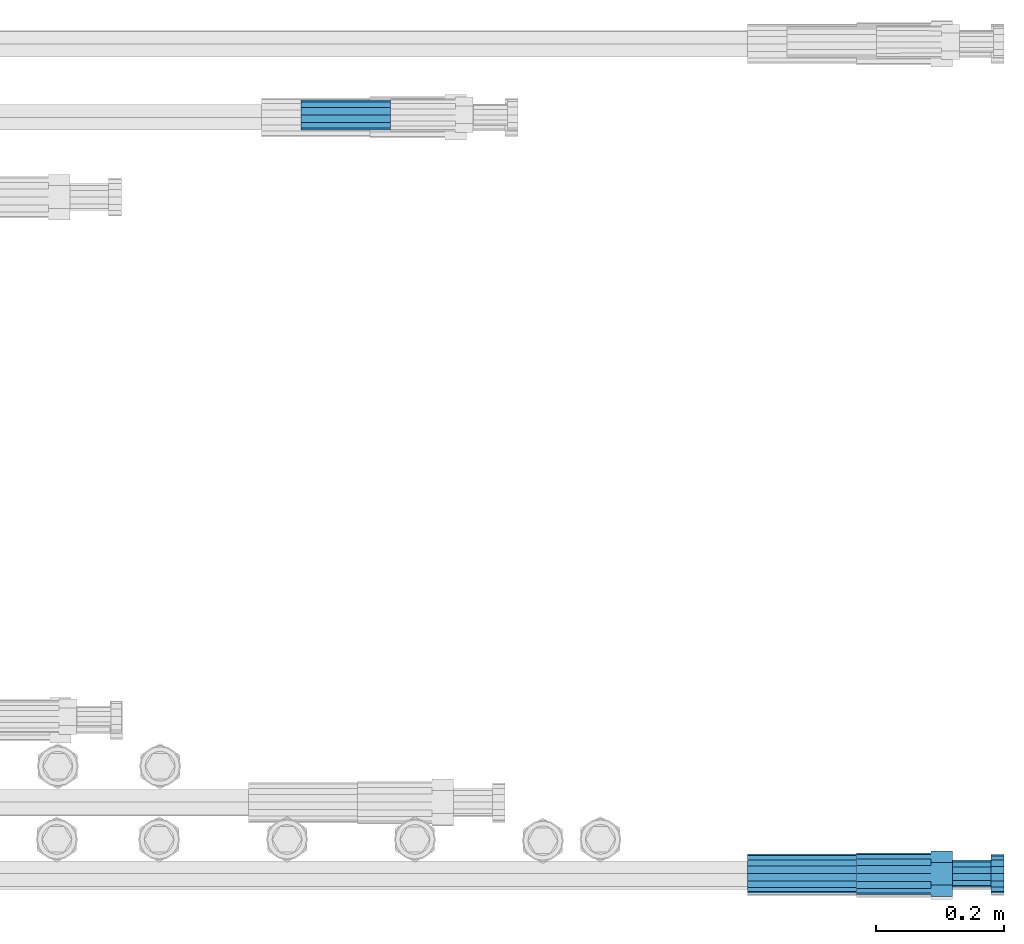
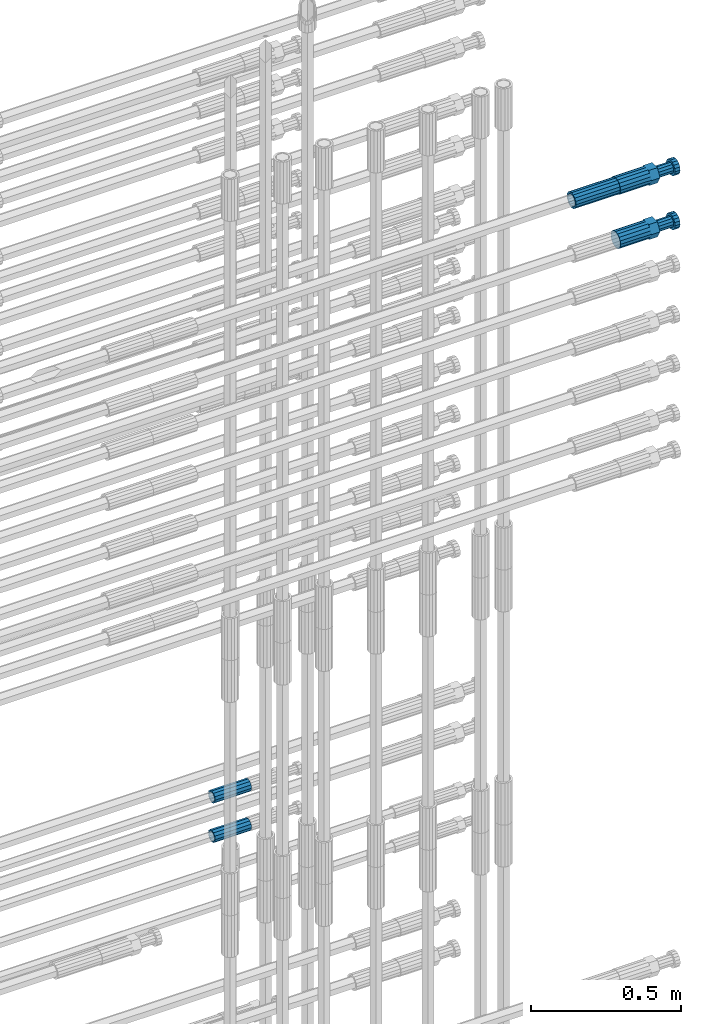
# One storey, part 107 of 119: 5 beams.
"""IFC2X3 building model written with IfcOpenShell, lengths in millimetres."""

from ifc_helpers import new_model, si_unit, frame, origin_with_axes, place, context, subcontext, project, spatial, faceted_brep, material, type_object, element, save


model = new_model("IFC2X3")

# Units and contexts
model_context = context("Model", 3, precision=1e-05, world=origin_with_axes())
body_context = subcontext(model_context, "Body", "Model", "MODEL_VIEW")
ifc_project = project(units=[si_unit("LENGTHUNIT", "METRE", prefix="MILLI"), si_unit("AREAUNIT", "SQUARE_METRE"), si_unit("VOLUMEUNIT", "CUBIC_METRE"), si_unit("MASSUNIT", "GRAM", prefix="KILO"), si_unit("TIMEUNIT", "SECOND"), si_unit("PLANEANGLEUNIT", "RADIAN"), si_unit("SOLIDANGLEUNIT", "STERADIAN"), si_unit("THERMODYNAMICTEMPERATUREUNIT", "DEGREE_CELSIUS"), si_unit("LUMINOUSINTENSITYUNIT", "LUMEN")], contexts=[model_context])

# Site, building, storey
site_placement = place(None, origin_with_axes())
site = spatial("IfcSite", under=ifc_project, at=site_placement, CompositionType="ELEMENT")
building_placement = place(site_placement, origin_with_axes())
building = spatial("IfcBuilding", under=site, at=building_placement, Name="Undefined", CompositionType="ELEMENT")
storey_placement = place(building_placement, origin_with_axes())
storey = spatial("IfcBuildingStorey", under=building, at=storey_placement, Name="Undefined", CompositionType="ELEMENT", Elevation=0.0)

# Beams
ifc_material = material(Name="STEEL/S275")
beam_type_1 = type_object("IfcBeamType", PredefinedType="NOTDEFINED")
beam_1_placement = place(storey_placement, frame((2039349.03023304, 6205102.98994599, 22308.9894123177), z_axis=(0.0, 0.0, 1.0), x_axis=(1.0, 0.0, 0.0)))
element("IfcBeam", 1, at=beam_1_placement, inside=storey, type_object=beam_type_1, material=ifc_material, Name="AG40N", context=body_context, shape_type="Brep", body=[
    faceted_brep([(1.62981450557709e-09, -23.4999999990687, 0.0), (7.45058059692383e-09, -21.7111690142192, 8.99306066057534), (170.000002125278, -21.711168999318, 8.99306066022245), (170.000002127141, -23.4999999844003, -3.66071617463604e-10), (4.65661287307739e-09, -16.6170093587134, 16.6170093578889), (170.000002122484, -16.6170093440451, 16.6170093575288), (1.86264514923096e-09, -8.99306066217832, 21.7111690140277), (170.000002118759, -8.99306064750999, 21.7111690136603), (2.3283064365387e-10, 9.31322574615479e-10, 23.5), (170.000002114102, 1.28056854009628e-08, 23.4999999996485), (-6.51925802230835e-09, 8.99306065868586, 21.7111690140241), (170.00000211224, 8.99306067335419, 21.7111690136639), (-7.45058059692383e-09, 16.6170093561523, 16.6170093578853), (170.000002109446, 16.6170093708206, 16.6170093575324), (-9.31322574615479e-09, 21.711169013055, 8.99306066057534), (170.000002108514, 21.7111690277234, 8.99306066022245), (-1.16415321826935e-09, 23.5000000009313, 0.0), (170.000002108514, 23.5000000144355, -3.66071617463604e-10), (-8.38190317153931e-09, 21.7111690151505, -8.99306066059444), (170.000002110377, 21.7111690300517, -8.9930606609546), (-5.58793544769287e-09, 16.6170093598776, -16.6170093579008), (170.000002113171, 16.6170093745459, -16.6170093582609), (-9.31322574615479e-10, 8.99306066334248, -21.7111690140396), (170.000002115965, 8.99306067801081, -21.7111690143961), (2.3283064365387e-10, 9.31322574615479e-10, -23.5), (170.00000211969, 1.7927959561348e-08, -23.5000000003843), (5.58793544769287e-09, -8.99306065752171, -21.7111690140396), (170.000002123415, -8.99306064285338, -21.7111690143961), (8.38190317153931e-09, -16.6170093549881, -16.6170093579008), (170.000002125278, -16.6170093403198, -16.6170093582646), (9.31322574615479e-09, -21.7111690121237, -8.99306066059444), (170.000002127141, -21.7111689972226, -8.9930606609546), (1.11758708953857e-08, -30.4999999990687, -9.54969436861575e-12), (1.30385160446167e-08, -28.1783257392235, -11.6718446871514), (170.000002129003, -28.1783257243223, -11.6718446875116), (170.000002129935, -30.4999999841675, -3.66071617463604e-10), (1.02445483207703e-08, -21.5667568228673, -21.5667568262129), (170.000002128072, -21.566756808199, -21.5667568265694), (7.45058059692383e-09, -11.6718446831219, -28.1783257416196), (170.000002125278, -11.6718446684536, -28.1783257419834), (3.72529029846191e-09, 3.95812094211578e-09, -30.5000000000277), (170.00000211969, 1.83936208486557e-08, -30.5000000003879), (-9.31322574615479e-10, 11.6718446905725, -28.1783257416232), (170.000002115965, 11.6718447052408, -28.1783257419797), (-6.51925802230835e-09, 21.5667568286881, -21.5667568262093), (170.000002110377, 21.5667568433564, -21.5667568265694), (-9.31322574615479e-09, 28.178325742716, -11.6718446871478), (170.000002108514, 28.1783257573843, -11.6718446875079), (-1.21071934700012e-08, 30.5, -5.91171556152403e-12), (170.000002106652, 30.5000000144355, -3.62433638656512e-10), (-1.21071934700012e-08, 28.1783257401548, 11.6718446871359), (170.00000210572, 28.1783257548232, 11.6718446867794), (-1.02445483207703e-08, 21.5667568240315, 21.5667568261974), (170.000002107583, 21.566756838467, 21.5667568258409), (-7.45058059692383e-09, 11.671844684286, 28.1783257416041), (170.000002110377, 11.6718446989544, 28.178325741244), (-2.79396772384644e-09, -2.56113708019257e-09, 30.5000000000159), (170.000002114102, 1.18743628263474e-08, 30.4999999996558), (1.86264514923096e-09, -11.6718446896411, 28.1783257416114), (170.000002118759, -11.67184467474, 28.178325741244), (7.45058059692383e-09, -21.5667568275239, 21.5667568261974), (170.000002123415, -21.5667568126228, 21.5667568258373), (1.02445483207703e-08, -28.1783257415518, 11.6718446871359), (170.000002127141, -28.1783257271163, 11.6718446867794)], [[[0, 1, 2, 3]], [[1, 4, 5, 2]], [[4, 6, 7, 5]], [[6, 8, 9, 7]], [[8, 10, 11, 9]], [[10, 12, 13, 11]], [[12, 14, 15, 13]], [[14, 16, 17, 15]], [[16, 18, 19, 17]], [[18, 20, 21, 19]], [[20, 22, 23, 21]], [[22, 24, 25, 23]], [[24, 26, 27, 25]], [[26, 28, 29, 27]], [[28, 30, 31, 29]], [[30, 0, 3, 31]], [[32, 33, 34, 35]], [[33, 36, 37, 34]], [[36, 38, 39, 37]], [[38, 40, 41, 39]], [[40, 42, 43, 41]], [[42, 44, 45, 43]], [[44, 46, 47, 45]], [[46, 48, 49, 47]], [[48, 50, 51, 49]], [[50, 52, 53, 51]], [[52, 54, 55, 53]], [[54, 56, 57, 55]], [[56, 58, 59, 57]], [[58, 60, 61, 59]], [[60, 62, 63, 61]], [[62, 32, 35, 63]], [[37, 39, 41, 43, 45, 47, 49, 51, 53, 55, 57, 59, 61, 63, 35, 34], [5, 7, 9, 11, 13, 15, 17, 19, 21, 23, 25, 27, 29, 31, 3, 2]], [[62, 60, 58, 56, 54, 52, 50, 48, 46, 44, 42, 40, 38, 36, 33, 32], [30, 28, 26, 24, 22, 20, 18, 16, 14, 12, 10, 8, 6, 4, 1, 0]]]),
])
beam_type_2 = type_object("IfcBeamType", Name="ROD65", PredefinedType="NOTDEFINED")
beam_2_placement = place(storey_placement, frame((2039519.03023304, 6205102.98994599, 22089.4694143809), z_axis=(0.0, 0.0, 1.0), x_axis=(1.0, 0.0, 0.0)))
element("IfcBeam", 2, at=beam_2_placement, inside=storey, type_object=beam_type_2, material=ifc_material, Name="AGB40", ObjectType="ROD65", context=body_context, shape_type="Brep", body=[
    faceted_brep([(116.999999999069, 17.8249999252148, 30.8738056446964), (116.999999998137, 22.0056957420893, 23.632628078838), (116.999999999069, 12.4372115600854, 30.0260848066173), (116.999999999069, 8.17543111252598, 30.8738056446964), (117.000000000931, -17.8250000746921, 30.8738056446964), (150.200000001118, -17.8250000723638, 30.8738056446964), (150.199999999255, 17.8249999275431, 30.8738056446964), (117.000000000931, -8.17543109622784, 30.8738056446964), (117.000000001863, -22.0056959956419, 23.6326278985034), (117.000000000931, -12.4372115437873, 30.0260848066173), (117.000000001863, -35.6500000746455, -2.18278728425503e-10), (150.200000002049, -35.6500000723172, -2.18278728425503e-10), (117.000000001863, -30.8443149488885, 8.32369080289209), (117.000000001863, -30.8443149488885, -8.32369080355784), (117.000000002794, -32.4999999918509, 0.0), (117.000000000931, -17.8250000746921, -30.873805645133), (150.200000001118, -17.8250000723638, -30.873805645133), (117.000000001863, -22.0056959961075, -23.6326278982269), (117.000000000931, -8.17543109389953, -30.873805645133), (117.000000000931, -12.4372115437873, -30.0260848066173), (116.999999999069, 17.8249999252148, -30.873805645133), (150.199999999255, 17.8249999275431, -30.873805645133), (116.999999999069, 8.17543111019768, -30.873805645133), (116.999999999069, 12.4372115600854, -30.0260848066173), (116.999999998137, 22.005695742555, -23.6326280785652), (116.999999998137, 35.6499999251682, -2.18278728425503e-10), (150.199999998324, 35.6499999277294, -2.18278728425503e-10), (116.999999998137, 30.8443150522653, -8.32369036550881), (116.999999997206, 32.5000000081491, 0.0), (116.999999998137, 30.8443150522653, 8.32369036483942), (1.86264514923096e-09, -22.9809703885112, 22.9809703885621), (1.86264514923096e-09, -30.0260848065373, 12.4372115518672), (117.000000001863, -30.0260847983882, 12.4372115518672), (117.000000001863, -22.9809703803621, 22.9809703885621), (-1.86264514923096e-09, 22.9809703885112, -22.9809703885621), (-1.86264514923096e-09, 30.0260848065373, -12.4372115518672), (116.999999998137, 30.0260848146863, -12.4372115518672), (116.999999998137, 22.9809703966603, -22.9809703885621), (1.86264514923096e-09, -30.0260848065373, -12.4372115518672), (1.86264514923096e-09, -22.9809703885112, -22.9809703885621), (117.000000001863, -22.9809703803621, -22.9809703885621), (117.000000001863, -30.0260847983882, -12.4372115518672), (9.31322574615479e-10, -12.4372115519363, 30.0260848066173), (0.0, 0.0, 32.5), (-9.31322574615479e-10, 12.4372115519363, 30.0260848066173), (-1.86264514923096e-09, 22.9809703885112, 22.9809703885621), (-1.86264514923096e-09, 30.0260848065373, 12.4372115518672), (-2.79396772384644e-09, 32.5, 0.0), (-9.31322574615479e-10, 12.4372115519363, -30.0260848066173), (0.0, 0.0, -32.5), (9.31322574615479e-10, -12.4372115519363, -30.0260848066173), (2.79396772384644e-09, -32.5, 0.0), (116.999999998137, 22.9809703966603, 22.9809703885621), (116.999999998137, 30.0260848146863, 12.4372115518672), (117.0, 8.14907252788544e-09, -32.5), (117.0, 8.14907252788544e-09, 32.5), (150.200000000186, -10.5000000959262, 18.1865334791873), (150.199999999255, -9.59262251853943e-08, 20.9999999997126), (150.199999998324, 10.4999999040738, 18.1865334791873), (150.199999997392, 18.1865333835594, 10.4999999997126), (150.199999997392, 20.9999999040738, -2.87400325760245e-10), (150.199999997392, 18.1865333835594, -10.5000000002874), (150.199999998324, 10.4999999040738, -18.1865334797621), (150.199999999255, -9.59262251853943e-08, -21.0000000002874), (150.200000000186, -10.5000000959262, -18.1865334797621), (150.200000000186, -18.1865335754119, -10.5000000002874), (150.200000001118, -21.0000000959262, -2.87400325760245e-10), (150.200000000186, -18.1865335754119, 10.4999999997126), (210.979999999516, 10.4999999082647, 18.1865334791873), (210.979999999516, -9.17352735996246e-08, 20.9999999997126), (210.979999997653, 18.1865333877504, 10.4999999997126), (210.979999997653, 20.9999999082647, -2.87400325760245e-10), (210.979999997653, 18.1865333877504, -10.5000000002874), (210.979999999516, 10.4999999082647, -18.1865334797621), (210.979999999516, -9.17352735996246e-08, -21.0000000002874), (210.979999999516, -10.5000000917353, -18.1865334797621), (210.980000000447, -18.1865335712209, -10.5000000002874), (210.980000001378, -21.0000000917353, -2.87400325760245e-10), (210.980000000447, -18.1865335712209, 10.4999999997126), (210.979999999516, -10.5000000917353, 18.1865334791873), (211.001368402503, -27.7269939335529, -11.4911163272045), (211.003082515672, -21.2238095656503, -21.2238154190527), (231.002518340945, -21.2131946226582, -21.2132004554769), (231.000804228708, -27.7163789905608, -11.4805013636287), (211.001368415542, -11.4911086384673, -27.7269970399575), (231.000804241747, -11.4804936954752, -27.7163820763781), (210.996487061493, -0.0106066407170147, -30.0106107396168), (230.995922887698, 8.30227509140968e-06, -29.999995776041), (210.98918159306, 11.4698940692469, -27.7269970332745), (230.988617419265, 11.4805090120062, -27.7163820696951), (210.980564201251, 21.2025913291145, -21.2238154067054), (230.980000027455, 21.2132062721066, -21.2132004431296), (210.971946807578, 27.7057702087332, -11.4911163110701), (230.971382633783, 27.7163851517253, -11.4805013474943), (210.964641331695, 29.9893806746695, -0.0106149565435771), (230.9640771579, 29.9999956176616, 7.03221303410828e-09), (210.959759964608, 27.7057637346443, 11.4698863966551), (230.959195790812, 27.7163786776364, 11.4805013602345), (210.958045851439, 21.2025793667417, 21.2025854885032), (230.957481677644, 21.2131943097338, 21.2132004520827), (210.959759951569, 11.4698784395587, 27.705767109408), (230.959195776843, 11.4804933823179, 27.7163820729838), (210.964641305618, -0.0106235581915826, 29.9893808090674), (230.964077131823, -8.61519947648048e-06, 29.9999957726432), (210.971946774051, -11.4911242681555, 27.7057671027251), (230.971382599324, -11.4805093251634, 27.7163820663009), (210.98056416586, -21.2238215280231, 21.2025854761559), (230.979999991134, -21.2132065852638, 21.2132004397354), (210.989181559533, -27.7270004076418, 11.4698863805206), (230.988617384806, -27.7163854646496, 11.4805013441), (210.996487035416, -30.0106108735781, -0.0106149740058754), (230.995922861621, -29.999995930586, -1.04300852399319e-08)], [[[0, 1, 2, 3]], [[4, 5, 6, 0, 3, 7]], [[8, 4, 7, 9]], [[10, 11, 5, 4, 8, 12]], [[13, 10, 12, 14]], [[15, 16, 11, 10, 13, 17]], [[18, 15, 17, 19]], [[20, 21, 16, 15, 18, 22]], [[20, 22, 23, 24]], [[25, 26, 21, 20, 24, 27]], [[25, 27, 28, 29]], [[30, 31, 32, 33]], [[34, 35, 36, 37]], [[38, 39, 40, 41]], [[31, 30, 42, 43, 44, 45, 46, 47, 35, 34, 48, 49, 50, 39, 38, 51]], [[46, 45, 52, 53]], [[28, 47, 46, 53, 29]], [[27, 36, 35, 47, 28]], [[24, 37, 36, 27]], [[23, 48, 34, 37, 24]], [[22, 54, 49, 48, 23]], [[18, 54, 22]], [[19, 50, 49, 54, 18]], [[17, 40, 39, 50, 19]], [[13, 41, 40, 17]], [[14, 51, 38, 41, 13]], [[12, 32, 31, 51, 14]], [[8, 33, 32, 12]], [[9, 42, 30, 33, 8]], [[7, 55, 43, 42, 9]], [[3, 55, 7]], [[2, 44, 43, 55, 3]], [[1, 52, 45, 44, 2]], [[29, 53, 52, 1]], [[0, 6, 26, 25, 29, 1]], [[5, 11, 16, 21, 26, 6], [56, 57, 58, 59, 60, 61, 62, 63, 64, 65, 66, 67]], [[68, 58, 57, 69]], [[70, 59, 58, 68]], [[71, 60, 59, 70]], [[72, 61, 60, 71]], [[73, 62, 61, 72]], [[74, 63, 62, 73]], [[75, 64, 63, 74]], [[76, 65, 64, 75]], [[77, 66, 65, 76]], [[78, 67, 66, 77]], [[79, 56, 67, 78]], [[69, 57, 56, 79]], [[80, 81, 82, 83]], [[81, 84, 85, 82]], [[84, 86, 87, 85]], [[86, 88, 89, 87]], [[88, 90, 91, 89]], [[90, 92, 93, 91]], [[92, 94, 95, 93]], [[94, 96, 97, 95]], [[96, 98, 99, 97]], [[98, 100, 101, 99]], [[100, 102, 103, 101]], [[102, 104, 105, 103]], [[104, 106, 107, 105]], [[106, 108, 109, 107]], [[108, 110, 111, 109]], [[82, 85, 87, 89, 91, 93, 95, 97, 99, 101, 103, 105, 107, 109, 111, 83]], [[110, 80, 83, 111]], [[108, 106, 104, 102, 100, 98, 96, 94, 92, 90, 88, 86, 84, 81, 80, 110], [78, 77, 76, 75, 74, 73, 72, 71, 70, 68, 69, 79]]]),
])
beam_3_placement = place(storey_placement, frame((2039519.03023304, 6205102.98994599, 22308.9894143943), z_axis=(0.0, 0.0, 1.0), x_axis=(1.0, 0.0, 0.0)))
element("IfcBeam", 3, at=beam_3_placement, inside=storey, type_object=beam_type_2, material=ifc_material, Name="AGB40", ObjectType="ROD65", context=body_context, shape_type="Brep", body=[
    faceted_brep([(116.999999999069, 17.8249999252148, 30.8738056446964), (116.999999998137, 22.0056957420893, 23.632628078838), (116.999999999069, 12.4372115600854, 30.0260848066173), (116.999999999069, 8.17543111252598, 30.8738056446964), (117.000000000931, -17.8250000746921, 30.8738056446964), (150.200000001118, -17.8250000723638, 30.8738056446964), (150.199999999255, 17.8249999275431, 30.8738056446964), (117.000000000931, -8.17543109622784, 30.8738056446964), (117.000000001863, -22.0056959956419, 23.6326278985034), (117.000000000931, -12.4372115437873, 30.0260848066173), (117.000000001863, -35.6500000746455, -2.18278728425503e-10), (150.200000002049, -35.6500000723172, -2.18278728425503e-10), (117.000000001863, -30.8443149488885, 8.32369080289209), (117.000000001863, -30.8443149488885, -8.32369080355784), (117.000000002794, -32.4999999918509, 0.0), (117.000000000931, -17.8250000746921, -30.873805645133), (150.200000001118, -17.8250000723638, -30.873805645133), (117.000000001863, -22.0056959961075, -23.6326278982269), (117.000000000931, -8.17543109389953, -30.873805645133), (117.000000000931, -12.4372115437873, -30.0260848066173), (116.999999999069, 17.8249999252148, -30.873805645133), (150.199999999255, 17.8249999275431, -30.873805645133), (116.999999999069, 8.17543111019768, -30.873805645133), (116.999999999069, 12.4372115600854, -30.0260848066173), (116.999999998137, 22.005695742555, -23.6326280785652), (116.999999998137, 35.6499999251682, -2.18278728425503e-10), (150.199999998324, 35.6499999277294, -2.18278728425503e-10), (116.999999998137, 30.8443150522653, -8.32369036550881), (116.999999997206, 32.5000000081491, 0.0), (116.999999998137, 30.8443150522653, 8.32369036483942), (1.86264514923096e-09, -22.9809703885112, 22.9809703885621), (1.86264514923096e-09, -30.0260848065373, 12.4372115518672), (117.000000001863, -30.0260847983882, 12.4372115518672), (117.000000001863, -22.9809703803621, 22.9809703885621), (-1.86264514923096e-09, 22.9809703885112, -22.9809703885621), (-1.86264514923096e-09, 30.0260848065373, -12.4372115518672), (116.999999998137, 30.0260848146863, -12.4372115518672), (116.999999998137, 22.9809703966603, -22.9809703885621), (1.86264514923096e-09, -30.0260848065373, -12.4372115518672), (1.86264514923096e-09, -22.9809703885112, -22.9809703885621), (117.000000001863, -22.9809703803621, -22.9809703885621), (117.000000001863, -30.0260847983882, -12.4372115518672), (9.31322574615479e-10, -12.4372115519363, 30.0260848066173), (0.0, 0.0, 32.5), (-9.31322574615479e-10, 12.4372115519363, 30.0260848066173), (-1.86264514923096e-09, 22.9809703885112, 22.9809703885621), (-1.86264514923096e-09, 30.0260848065373, 12.4372115518672), (-2.79396772384644e-09, 32.5, 0.0), (-9.31322574615479e-10, 12.4372115519363, -30.0260848066173), (0.0, 0.0, -32.5), (9.31322574615479e-10, -12.4372115519363, -30.0260848066173), (2.79396772384644e-09, -32.5, 0.0), (116.999999998137, 22.9809703966603, 22.9809703885621), (116.999999998137, 30.0260848146863, 12.4372115518672), (117.0, 8.14907252788544e-09, -32.5), (117.0, 8.14907252788544e-09, 32.5), (150.200000000186, -10.5000000959262, 18.1865334791873), (150.199999999255, -9.59262251853943e-08, 20.9999999997126), (150.199999998324, 10.4999999040738, 18.1865334791873), (150.199999997392, 18.1865333835594, 10.4999999997126), (150.199999997392, 20.9999999040738, -2.87400325760245e-10), (150.199999997392, 18.1865333835594, -10.5000000002874), (150.199999998324, 10.4999999040738, -18.1865334797621), (150.199999999255, -9.59262251853943e-08, -21.0000000002874), (150.200000000186, -10.5000000959262, -18.1865334797621), (150.200000000186, -18.1865335754119, -10.5000000002874), (150.200000001118, -21.0000000959262, -2.87400325760245e-10), (150.200000000186, -18.1865335754119, 10.4999999997126), (210.979999999516, 10.4999999082647, 18.1865334791873), (210.979999999516, -9.17352735996246e-08, 20.9999999997126), (210.979999997653, 18.1865333877504, 10.4999999997126), (210.979999997653, 20.9999999082647, -2.87400325760245e-10), (210.979999997653, 18.1865333877504, -10.5000000002874), (210.979999999516, 10.4999999082647, -18.1865334797621), (210.979999999516, -9.17352735996246e-08, -21.0000000002874), (210.979999999516, -10.5000000917353, -18.1865334797621), (210.980000000447, -18.1865335712209, -10.5000000002874), (210.980000001378, -21.0000000917353, -2.87400325760245e-10), (210.980000000447, -18.1865335712209, 10.4999999997126), (210.979999999516, -10.5000000917353, 18.1865334791873), (211.001368402503, -27.7269939335529, -11.4911163272045), (211.003082515672, -21.2238095656503, -21.2238154190527), (231.002518340945, -21.2131946226582, -21.2132004554769), (231.000804228708, -27.7163789905608, -11.4805013636287), (211.001368415542, -11.4911086384673, -27.7269970399575), (231.000804241747, -11.4804936954752, -27.7163820763781), (210.996487061493, -0.0106066407170147, -30.0106107396168), (230.995922887698, 8.30227509140968e-06, -29.999995776041), (210.98918159306, 11.4698940692469, -27.7269970332745), (230.988617419265, 11.4805090120062, -27.7163820696951), (210.980564201251, 21.2025913291145, -21.2238154067054), (230.980000027455, 21.2132062721066, -21.2132004431296), (210.971946807578, 27.7057702087332, -11.4911163110701), (230.971382633783, 27.7163851517253, -11.4805013474943), (210.964641331695, 29.9893806746695, -0.0106149565435771), (230.9640771579, 29.9999956176616, 7.03221303410828e-09), (210.959759964608, 27.7057637346443, 11.4698863966551), (230.959195790812, 27.7163786776364, 11.4805013602345), (210.958045851439, 21.2025793667417, 21.2025854885032), (230.957481677644, 21.2131943097338, 21.2132004520827), (210.959759951569, 11.4698784395587, 27.705767109408), (230.959195776843, 11.4804933823179, 27.7163820729838), (210.964641305618, -0.0106235581915826, 29.9893808090674), (230.964077131823, -8.61519947648048e-06, 29.9999957726432), (210.971946774051, -11.4911242681555, 27.7057671027251), (230.971382599324, -11.4805093251634, 27.7163820663009), (210.98056416586, -21.2238215280231, 21.2025854761559), (230.979999991134, -21.2132065852638, 21.2132004397354), (210.989181559533, -27.7270004076418, 11.4698863805206), (230.988617384806, -27.7163854646496, 11.4805013441), (210.996487035416, -30.0106108735781, -0.0106149740058754), (230.995922861621, -29.999995930586, -1.04300852399319e-08)], [[[0, 1, 2, 3]], [[4, 5, 6, 0, 3, 7]], [[8, 4, 7, 9]], [[10, 11, 5, 4, 8, 12]], [[13, 10, 12, 14]], [[15, 16, 11, 10, 13, 17]], [[18, 15, 17, 19]], [[20, 21, 16, 15, 18, 22]], [[20, 22, 23, 24]], [[25, 26, 21, 20, 24, 27]], [[25, 27, 28, 29]], [[30, 31, 32, 33]], [[34, 35, 36, 37]], [[38, 39, 40, 41]], [[31, 30, 42, 43, 44, 45, 46, 47, 35, 34, 48, 49, 50, 39, 38, 51]], [[46, 45, 52, 53]], [[28, 47, 46, 53, 29]], [[27, 36, 35, 47, 28]], [[24, 37, 36, 27]], [[23, 48, 34, 37, 24]], [[22, 54, 49, 48, 23]], [[18, 54, 22]], [[19, 50, 49, 54, 18]], [[17, 40, 39, 50, 19]], [[13, 41, 40, 17]], [[14, 51, 38, 41, 13]], [[12, 32, 31, 51, 14]], [[8, 33, 32, 12]], [[9, 42, 30, 33, 8]], [[7, 55, 43, 42, 9]], [[3, 55, 7]], [[2, 44, 43, 55, 3]], [[1, 52, 45, 44, 2]], [[29, 53, 52, 1]], [[0, 6, 26, 25, 29, 1]], [[5, 11, 16, 21, 26, 6], [56, 57, 58, 59, 60, 61, 62, 63, 64, 65, 66, 67]], [[68, 58, 57, 69]], [[70, 59, 58, 68]], [[71, 60, 59, 70]], [[72, 61, 60, 71]], [[73, 62, 61, 72]], [[74, 63, 62, 73]], [[75, 64, 63, 74]], [[76, 65, 64, 75]], [[77, 66, 65, 76]], [[78, 67, 66, 77]], [[79, 56, 67, 78]], [[69, 57, 56, 79]], [[80, 81, 82, 83]], [[81, 84, 85, 82]], [[84, 86, 87, 85]], [[86, 88, 89, 87]], [[88, 90, 91, 89]], [[90, 92, 93, 91]], [[92, 94, 95, 93]], [[94, 96, 97, 95]], [[96, 98, 99, 97]], [[98, 100, 101, 99]], [[100, 102, 103, 101]], [[102, 104, 105, 103]], [[104, 106, 107, 105]], [[106, 108, 109, 107]], [[108, 110, 111, 109]], [[82, 85, 87, 89, 91, 93, 95, 97, 99, 101, 103, 105, 107, 109, 111, 83]], [[110, 80, 83, 111]], [[108, 106, 104, 102, 100, 98, 96, 94, 92, 90, 88, 86, 84, 81, 80, 110], [78, 77, 76, 75, 74, 73, 72, 71, 70, 68, 69, 79]]]),
])
beam_type_3 = type_object("IfcBeamType", PredefinedType="NOTDEFINED")
beam_4_placement = place(storey_placement, frame((2038651.00023304, 6206289.47994599, 19249.4894170109), z_axis=(0.0, 0.0, 1.0), x_axis=(1.0, 0.0, 0.0)))
element("IfcBeam", 4, at=beam_4_placement, inside=storey, type_object=beam_type_3, material=ifc_material, Name="AG32N", context=body_context, shape_type="Brep", body=[
    faceted_brep([(1.39698386192322e-09, -18.4999999990687, 0.0), (1.16415321826935e-09, -16.0214699693024, 9.25), (140.000000001164, -16.0214699935168, 9.25), (140.000000001397, -18.5000000232831, 0.0), (6.98491930961609e-10, -9.24999999906868, 16.0214699700118), (140.000000000698, -9.25000002328306, 16.0214699700118), (2.3283064365387e-10, 9.31322574615479e-10, 18.5), (140.000000000233, -2.3283064365387e-08, 18.5), (-2.3283064365387e-10, 9.25000000093132, 16.0214699700118), (139.999999999767, 9.24999997671694, 16.0214699700118), (-6.98491930961609e-10, 16.0214699711651, 9.25), (139.999999999302, 16.0214699469507, 9.25), (-9.31322574615479e-10, 18.5000000009313, 0.0), (139.999999999069, 18.4999999767169, 0.0), (-6.98491930961609e-10, 16.0214699711651, -9.25), (139.999999999302, 16.0214699469507, -9.25), (-2.3283064365387e-10, 9.25000000093132, -16.0214699700118), (139.999999999767, 9.24999997671694, -16.0214699700118), (2.3283064365387e-10, 9.31322574615479e-10, -18.5), (140.000000000233, -2.3283064365387e-08, -18.5), (6.98491930961609e-10, -9.24999999906868, -16.0214699700118), (140.000000000698, -9.25000002328306, -16.0214699700118), (1.16415321826935e-09, -16.0214699693024, -9.25), (140.000000001164, -16.0214699935168, -9.25), (1.62981450557709e-09, -23.4999999990687, 0.0), (1.39698386192322e-09, -20.3515969878063, -11.75), (140.000000001397, -20.3515970120206, -11.75), (140.00000000163, -23.5000000232831, 0.0), (9.31322574615479e-10, -11.7499999990687, -20.351596988934), (140.000000000931, -11.7500000232831, -20.351596988934), (2.3283064365387e-10, 9.31322574615479e-10, -23.5), (140.000000000233, -2.3283064365387e-08, -23.5), (-4.65661287307739e-10, 11.7500000009313, -20.351596988934), (139.999999999534, 11.7499999767169, -20.351596988934), (-9.31322574615479e-10, 20.3515969896689, -11.75), (139.999999999069, 20.3515969654545, -11.75), (-1.16415321826935e-09, 23.5000000009313, 0.0), (139.999999998836, 23.4999999767169, 0.0), (-9.31322574615479e-10, 20.3515969896689, 11.75), (139.999999999069, 20.3515969654545, 11.75), (-4.65661287307739e-10, 11.7500000009313, 20.351596988934), (139.999999999534, 11.7499999767169, 20.351596988934), (2.3283064365387e-10, 9.31322574615479e-10, 23.5), (140.000000000233, -2.3283064365387e-08, 23.5), (9.31322574615479e-10, -11.7499999990687, 20.351596988934), (140.000000000931, -11.7500000232831, 20.351596988934), (1.39698386192322e-09, -20.3515969878063, 11.75), (140.000000001397, -20.3515970120206, 11.75)], [[[0, 1, 2, 3]], [[1, 4, 5, 2]], [[4, 6, 7, 5]], [[6, 8, 9, 7]], [[8, 10, 11, 9]], [[10, 12, 13, 11]], [[12, 14, 15, 13]], [[14, 16, 17, 15]], [[16, 18, 19, 17]], [[18, 20, 21, 19]], [[20, 22, 23, 21]], [[22, 0, 3, 23]], [[24, 25, 26, 27]], [[25, 28, 29, 26]], [[28, 30, 31, 29]], [[30, 32, 33, 31]], [[32, 34, 35, 33]], [[34, 36, 37, 35]], [[36, 38, 39, 37]], [[38, 40, 41, 39]], [[40, 42, 43, 41]], [[42, 44, 45, 43]], [[44, 46, 47, 45]], [[46, 24, 27, 47]], [[29, 31, 33, 35, 37, 39, 41, 43, 45, 47, 27, 26], [5, 7, 9, 11, 13, 15, 17, 19, 21, 23, 3, 2]], [[46, 44, 42, 40, 38, 36, 34, 32, 30, 28, 25, 24], [22, 20, 18, 16, 14, 12, 10, 8, 6, 4, 1, 0]]]),
])
beam_5_placement = place(storey_placement, frame((2038651.00023304, 6206289.47994599, 19409.4894170109), z_axis=(0.0, 0.0, 1.0), x_axis=(1.0, 0.0, 0.0)))
element("IfcBeam", 5, at=beam_5_placement, inside=storey, type_object=beam_type_3, material=ifc_material, Name="AG32N", context=body_context, shape_type="Brep", body=[
    faceted_brep([(1.39698386192322e-09, -18.4999999990687, 0.0), (1.16415321826935e-09, -16.0214699693024, 9.25), (140.000000001164, -16.0214699935168, 9.25), (140.000000001397, -18.5000000232831, 0.0), (6.98491930961609e-10, -9.24999999906868, 16.0214699700118), (140.000000000698, -9.25000002328306, 16.0214699700118), (2.3283064365387e-10, 9.31322574615479e-10, 18.5), (140.000000000233, -2.3283064365387e-08, 18.5), (-2.3283064365387e-10, 9.25000000093132, 16.0214699700118), (139.999999999767, 9.24999997671694, 16.0214699700118), (-6.98491930961609e-10, 16.0214699711651, 9.25), (139.999999999302, 16.0214699469507, 9.25), (-9.31322574615479e-10, 18.5000000009313, 0.0), (139.999999999069, 18.4999999767169, 0.0), (-6.98491930961609e-10, 16.0214699711651, -9.25), (139.999999999302, 16.0214699469507, -9.25), (-2.3283064365387e-10, 9.25000000093132, -16.0214699700118), (139.999999999767, 9.24999997671694, -16.0214699700118), (2.3283064365387e-10, 9.31322574615479e-10, -18.5), (140.000000000233, -2.3283064365387e-08, -18.5), (6.98491930961609e-10, -9.24999999906868, -16.0214699700118), (140.000000000698, -9.25000002328306, -16.0214699700118), (1.16415321826935e-09, -16.0214699693024, -9.25), (140.000000001164, -16.0214699935168, -9.25), (1.62981450557709e-09, -23.4999999990687, 0.0), (1.39698386192322e-09, -20.3515969878063, -11.75), (140.000000001397, -20.3515970120206, -11.75), (140.00000000163, -23.5000000232831, 0.0), (9.31322574615479e-10, -11.7499999990687, -20.351596988934), (140.000000000931, -11.7500000232831, -20.351596988934), (2.3283064365387e-10, 9.31322574615479e-10, -23.5), (140.000000000233, -2.3283064365387e-08, -23.5), (-4.65661287307739e-10, 11.7500000009313, -20.351596988934), (139.999999999534, 11.7499999767169, -20.351596988934), (-9.31322574615479e-10, 20.3515969896689, -11.75), (139.999999999069, 20.3515969654545, -11.75), (-1.16415321826935e-09, 23.5000000009313, 0.0), (139.999999998836, 23.4999999767169, 0.0), (-9.31322574615479e-10, 20.3515969896689, 11.75), (139.999999999069, 20.3515969654545, 11.75), (-4.65661287307739e-10, 11.7500000009313, 20.351596988934), (139.999999999534, 11.7499999767169, 20.351596988934), (2.3283064365387e-10, 9.31322574615479e-10, 23.5), (140.000000000233, -2.3283064365387e-08, 23.5), (9.31322574615479e-10, -11.7499999990687, 20.351596988934), (140.000000000931, -11.7500000232831, 20.351596988934), (1.39698386192322e-09, -20.3515969878063, 11.75), (140.000000001397, -20.3515970120206, 11.75)], [[[0, 1, 2, 3]], [[1, 4, 5, 2]], [[4, 6, 7, 5]], [[6, 8, 9, 7]], [[8, 10, 11, 9]], [[10, 12, 13, 11]], [[12, 14, 15, 13]], [[14, 16, 17, 15]], [[16, 18, 19, 17]], [[18, 20, 21, 19]], [[20, 22, 23, 21]], [[22, 0, 3, 23]], [[24, 25, 26, 27]], [[25, 28, 29, 26]], [[28, 30, 31, 29]], [[30, 32, 33, 31]], [[32, 34, 35, 33]], [[34, 36, 37, 35]], [[36, 38, 39, 37]], [[38, 40, 41, 39]], [[40, 42, 43, 41]], [[42, 44, 45, 43]], [[44, 46, 47, 45]], [[46, 24, 27, 47]], [[29, 31, 33, 35, 37, 39, 41, 43, 45, 47, 27, 26], [5, 7, 9, 11, 13, 15, 17, 19, 21, 23, 3, 2]], [[46, 44, 42, 40, 38, 36, 34, 32, 30, 28, 25, 24], [22, 20, 18, 16, 14, 12, 10, 8, 6, 4, 1, 0]]]),
])

save(model, "model.ifc")
